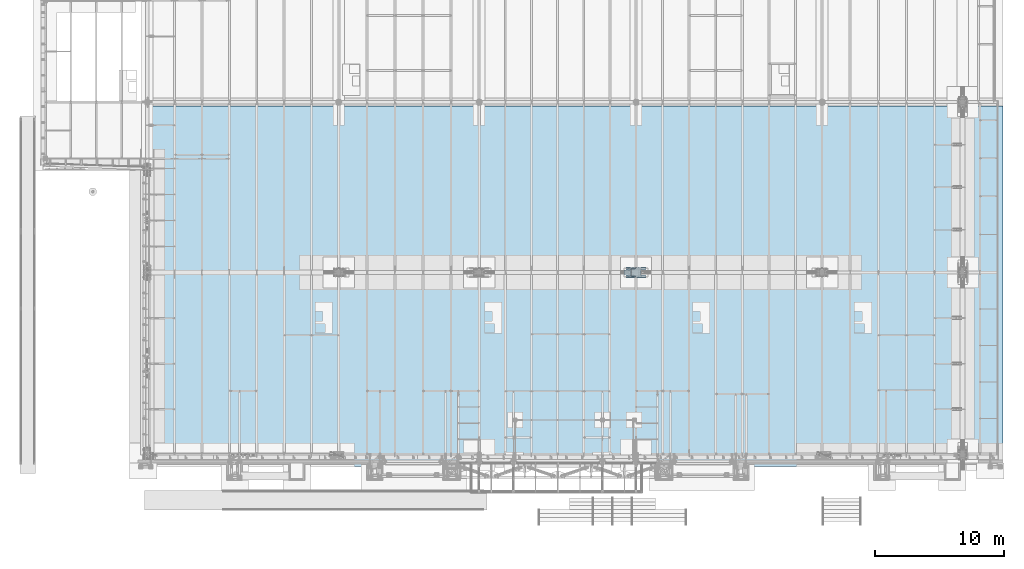
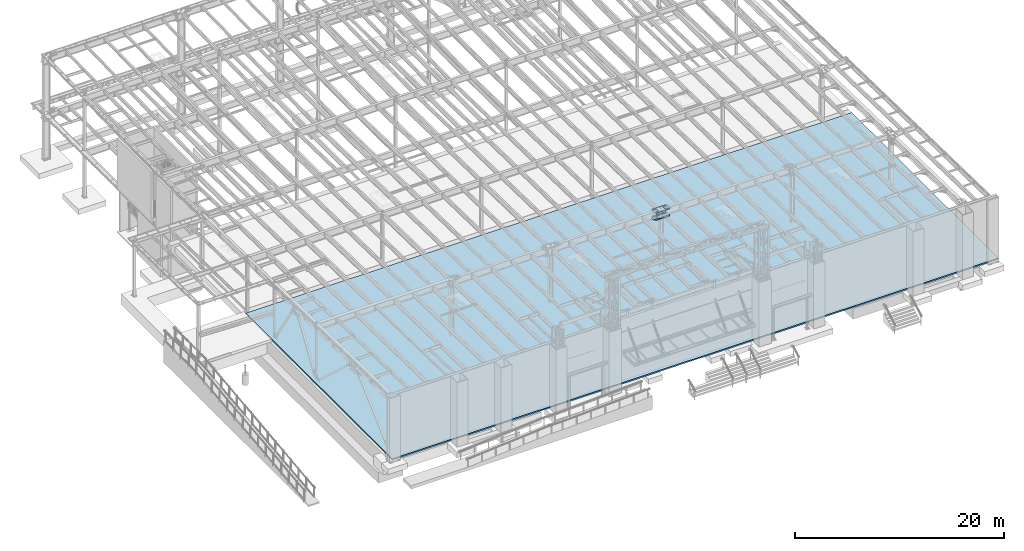
# One storey, part 1411 of 1763: 4 plates, 1 slab, 3 elements without a shape of their own.
"""IFC2X3 building model written with IfcOpenShell, lengths in millimetres."""

from ifc_helpers import new_model, si_unit, frame, origin_with_axes, place, context, subcontext, project, spatial, faceted_brep, material, type_object, element, aggregate, save


model = new_model("IFC2X3")

# Units and contexts
model_context = context("Model", 3, precision=1e-05, world=origin_with_axes())
body_context = subcontext(model_context, "Body", "Model", "MODEL_VIEW")
ifc_project = project(units=[si_unit("LENGTHUNIT", "METRE", prefix="MILLI"), si_unit("AREAUNIT", "SQUARE_METRE"), si_unit("VOLUMEUNIT", "CUBIC_METRE"), si_unit("MASSUNIT", "GRAM", prefix="KILO"), si_unit("TIMEUNIT", "SECOND"), si_unit("PLANEANGLEUNIT", "RADIAN"), si_unit("SOLIDANGLEUNIT", "STERADIAN"), si_unit("THERMODYNAMICTEMPERATUREUNIT", "DEGREE_CELSIUS"), si_unit("LUMINOUSINTENSITYUNIT", "LUMEN")], contexts=[model_context])

# Site, building, storey
site_placement = place(None, origin_with_axes())
site = spatial("IfcSite", under=ifc_project, at=site_placement, CompositionType="ELEMENT")
building_placement = place(site_placement, origin_with_axes())
building = spatial("IfcBuilding", under=site, at=building_placement, Name="Undefined", CompositionType="ELEMENT")
storey_placement = place(building_placement, origin_with_axes())
storey = spatial("IfcBuildingStorey", under=building, at=storey_placement, Name="Undefined", CompositionType="ELEMENT", Elevation=0.0)

# Assembly, plate
assembly_1_placement = place(storey_placement, origin_with_axes())
assembly_1 = element("IfcElementAssembly", 1, at=assembly_1_placement, inside=storey, Name="PLATE", AssemblyPlace="NOTDEFINED", PredefinedType="RIGID_FRAME")
ifc_material_1 = material(Name="STEEL/A572-50")
plate_type_1 = type_object("IfcPlateType", PredefinedType="NOTDEFINED")
plate_1_placement = place(assembly_1_placement, frame((-49446.8822232163, 96.8375244136021, 11057.4961714753), z_axis=(-1.0, 0.0, 0.0), x_axis=(0.0, 1.0, 0.0)))
plate_1 = element("IfcPlate", 2, at=plate_1_placement, type_object=plate_type_1, material=ifc_material_1, Name="PLATE", context=body_context, shape_type="Brep", body=[
    faceted_brep([(177.799939142153, -9.52499999999964, 479.364864346178), (177.799939142153, 9.52499999999964, 479.364864346178), (175.935192487686, 9.52499999999964, 467.591317332008), (175.935192487686, -9.52499999999964, 467.591317332008), (170.523486919264, 9.52499999999964, 456.97024713071), (170.523486919264, -9.52499999999964, 456.97024713071), (162.094557883494, 9.52499999999964, 448.541318094933), (162.094557883494, -9.52499999999964, 448.541318094933), (151.4734876822, 9.52499999999964, 443.1296125265), (151.4734876822, -9.52499999999964, 443.1296125265), (139.699940668032, 9.52499999999964, 441.264865872028), (139.699940668032, -9.52499999999964, 441.264865872028), (127.926386024366, 9.52499999999964, 443.1296125265), (127.926386024366, -9.52499999999964, 443.1296125265), (117.305315823075, 9.52499999999964, 448.541318094925), (117.305315823075, -9.52499999999964, 448.541318094925), (108.876386787306, 9.52499999999964, 456.970247130695), (108.876386787306, -9.52499999999964, 456.970247130695), (103.464681218881, 9.52499999999964, 467.591317331986), (103.464681218881, -9.52499999999964, 467.591317331986), (101.599934564408, 9.52499999999964, 479.364864346149), (101.599934564408, -9.52499999999964, 479.364864346149), (101.599934564408, 9.52499999999964, 600.014873502398), (101.599934564408, -9.52499999999964, 600.014873502398), (103.464681218941, 9.52499999999964, 611.788420516743), (103.464681218941, -9.52499999999964, 611.788420516743), (108.876386787534, 9.52499999999964, 622.409490718164), (108.876386787534, -9.52499999999964, 622.409490718164), (117.305315823547, 9.52499999999964, 630.838419753964), (117.305315823547, -9.52499999999964, 630.838419753964), (127.926386025105, 9.52499999999964, 636.25012532228), (127.926386025105, -9.52499999999964, 636.25012532228), (139.699940668921, 9.52499999999964, 638.114871976519), (139.699940668921, -9.52499999999964, 638.114871976519), (151.473487682847, 9.52499999999964, 636.250125321807), (151.473487682847, -9.52499999999964, 636.250125321807), (162.094557883867, 9.52499999999964, 630.83841975328), (162.094557883867, -9.52499999999964, 630.83841975328), (170.523486919393, 9.52499999999964, 622.409490717546), (170.523486919393, -9.52499999999964, 622.409490717546), (175.935192487652, 9.52499999999964, 611.788420516394), (175.935192487652, -9.52499999999964, 611.788420516394), (177.799939142071, 9.52499999999964, 600.01487350242), (177.799939142071, -9.52499999999964, 600.01487350242), (542.924972534173, -9.52499999999964, 885.855102539062), (542.924972534173, 9.52499999999964, 885.855102539062), (177.800003051751, 9.52499999999964, 885.855102539062), (177.800003051751, -9.52499999999964, 885.855063622585), (542.924972534173, -9.52499999999964, 752.414870449502), (542.924972534173, 9.52499999999964, 752.414870449502), (544.789719188646, -9.52499999999964, 740.641323435339), (544.789719188646, 9.52499999999964, 740.641323435339), (550.20142475707, -9.52499999999964, 730.020253234048), (550.20142475707, 9.52499999999964, 730.020253234048), (558.63035379284, -9.52499999999964, 721.591324198278), (558.63035379284, 9.52499999999964, 721.591324198278), (569.251423994131, -9.52499999999964, 716.179618629852), (569.251423994131, 9.52499999999964, 716.179618629852), (581.024971008294, -9.52499999999964, 714.314871975381), (581.024971008294, 9.52499999999964, 714.314871975381), (720.724975586481, -9.52499999999964, 714.314871975381), (720.724975585938, 9.52499999999964, 714.314871975381), (720.724975585938, -9.52499999999964, 7.27595761418343e-12), (720.724975585938, 9.52499999999964, 7.27595761418343e-12), (619.125, -9.52499999999964, 0.0), (619.125, 9.52499999999964, 0.0), (619.124958978549, -9.52499999999964, 326.964881896973), (619.124958978549, 9.52499999999964, 326.964881896973), (617.260212324076, -9.52499999999964, 338.738428911136), (617.260212324076, 9.52499999999964, 338.738428911136), (611.848506755652, -9.52499999999964, 349.359499112426), (611.848506755652, 9.52499999999964, 349.359499112426), (603.419577719882, -9.52499999999964, 357.788428148197), (603.419577719882, 9.52499999999964, 357.788428148197), (592.798507518591, -9.52499999999964, 363.200133716622), (592.798507518591, 9.52499999999964, 363.200133716622), (581.024960504428, -9.52499999999964, 365.064880371094), (581.024960504428, 9.52499999999964, 365.064880371094), (139.699933038564, -9.52499999999964, 365.064880371094), (139.699933038564, 9.52499999999964, 365.064880371094), (127.9263860244, -9.52499999999964, 363.200133716622), (127.9263860244, 9.52499999999964, 363.200133716622), (117.305315823109, -9.52499999999964, 357.788428148197), (117.305315823109, 9.52499999999964, 357.788428148197), (108.876386787339, -9.52499999999964, 349.359499112426), (108.876386787339, 9.52499999999964, 349.359499112426), (103.464681218915, -9.52499999999964, 338.738428911129), (103.464681218915, 9.52499999999964, 338.738428911129), (101.599934564443, -9.52499999999964, 326.964881896965), (101.599934564443, 9.52499999999964, 326.964881896965), (101.599934564487, -9.52499999999964, 0.0), (101.599934564487, 9.52499999999964, 0.0), (0.0, -9.52500000000146, 0.0), (0.0, 9.52500000000146, 0.0), (-3.68345354218036e-11, -9.52499999999964, 714.314871972194), (-3.68345354218036e-11, 9.52499999999964, 714.314871972194), (139.700004577691, -9.52499999999964, 714.314871972194), (139.700004577691, 9.52499999999964, 714.314871972194), (151.473551591857, -9.52499999999964, 716.179618626666), (151.473551591857, 9.52499999999964, 716.179618626666), (162.094621793151, -9.52499999999964, 721.591324195098), (162.094621793151, 9.52499999999964, 721.591324195098), (170.523550828921, -9.52499999999964, 730.020253230869), (170.523550828921, 9.52499999999964, 730.020253230869), (175.935256397344, -9.52499999999964, 740.641323432166), (175.935256397344, 9.52499999999964, 740.641323432166), (177.800003051812, -9.52499999999964, 752.41487044633), (177.800003051812, 9.52499999999964, 752.41487044633), (617.260212324486, -9.52499999999964, 467.591317332102), (611.848506756063, -9.52499999999964, 456.970247130805), (603.419577720293, -9.52499999999964, 448.541318095035), (592.798507519, -9.52499999999964, 443.129612526602), (581.024960504833, -9.52499999999964, 441.26486587213), (569.251405861195, -9.52499999999964, 443.129612526602), (558.630335659904, -9.52499999999964, 448.541318095027), (550.201406624135, -9.52499999999964, 456.970247130797), (544.78970105571, -9.52499999999964, 467.591317332088), (542.924954401237, -9.52499999999964, 479.364864346251), (542.924954401237, -9.52499999999964, 600.014873502478), (544.789701055769, -9.52499999999964, 611.788420516823), (550.201406624359, -9.52499999999964, 622.409490718237), (558.630335660367, -9.52499999999964, 630.838419754036), (569.25140586192, -9.52499999999964, 636.25012532236), (581.024960505725, -9.52499999999964, 638.114871976599), (592.798507519656, -9.52499999999964, 636.250125321894), (603.419577720682, -9.52499999999964, 630.838419753367), (611.848506756213, -9.52499999999964, 622.409490717633), (617.260212324474, -9.52499999999964, 611.788420516474), (619.124958978893, -9.52499999999964, 600.0148735025), (619.124958978954, -9.52499999999964, 479.364864346273), (611.848506756213, 9.52499999999964, 622.409490717633), (617.260212324474, 9.52499999999964, 611.788420516474), (603.419577720682, 9.52499999999964, 630.838419753367), (592.798507519656, 9.52499999999964, 636.250125321894), (581.024960505725, 9.52499999999964, 638.114871976599), (569.25140586192, 9.52499999999964, 636.25012532236), (558.630335660367, 9.52499999999964, 630.838419754036), (550.201406624359, 9.52499999999964, 622.409490718237), (544.789701055769, 9.52499999999964, 611.788420516823), (542.924954401237, 9.52499999999964, 600.014873502478), (542.924954401237, 9.52499999999964, 479.364864346251), (544.78970105571, 9.52499999999964, 467.591317332088), (550.201406624135, 9.52499999999964, 456.970247130797), (558.630335659904, 9.52499999999964, 448.541318095027), (569.251405861195, 9.52499999999964, 443.129612526602), (581.024960504833, 9.52499999999964, 441.26486587213), (592.798507519, 9.52499999999964, 443.129612526602), (603.419577720293, 9.52499999999964, 448.541318095035), (611.848506756063, 9.52499999999964, 456.970247130805), (617.260212324486, 9.52499999999964, 467.591317332102), (619.124958978954, 9.52499999999964, 479.364864346273), (619.124958978893, 9.52499999999964, 600.0148735025)], [[[0, 1, 2, 3]], [[3, 2, 4, 5]], [[5, 4, 6, 7]], [[7, 6, 8, 9]], [[9, 8, 10, 11]], [[11, 10, 12, 13]], [[13, 12, 14, 15]], [[15, 14, 16, 17]], [[17, 16, 18, 19]], [[19, 18, 20, 21]], [[21, 20, 22, 23]], [[23, 22, 24, 25]], [[25, 24, 26, 27]], [[27, 26, 28, 29]], [[29, 28, 30, 31]], [[31, 30, 32, 33]], [[33, 32, 34, 35]], [[35, 34, 36, 37]], [[37, 36, 38, 39]], [[39, 38, 40, 41]], [[41, 40, 42, 43]], [[43, 42, 1, 0]], [[44, 45, 46, 47]], [[44, 48, 49, 45]], [[50, 51, 49, 48]], [[52, 53, 51, 50]], [[54, 55, 53, 52]], [[56, 57, 55, 54]], [[58, 59, 57, 56]], [[60, 61, 59, 58]], [[62, 63, 61, 60]], [[63, 62, 64, 65]], [[66, 67, 65, 64]], [[68, 69, 67, 66]], [[70, 71, 69, 68]], [[72, 73, 71, 70]], [[74, 75, 73, 72]], [[76, 77, 75, 74]], [[78, 79, 77, 76]], [[80, 81, 79, 78]], [[82, 83, 81, 80]], [[84, 85, 83, 82]], [[86, 87, 85, 84]], [[88, 89, 87, 86]], [[90, 91, 89, 88]], [[92, 93, 91, 90]], [[93, 92, 94, 95]], [[96, 97, 95, 94]], [[98, 99, 97, 96]], [[100, 101, 99, 98]], [[102, 103, 101, 100]], [[104, 105, 103, 102]], [[106, 107, 105, 104]], [[47, 46, 107, 106]], [[104, 102, 100, 98, 96, 94, 92, 90, 88, 86, 84, 82, 80, 78, 76, 74, 72, 70, 68, 66, 64, 62, 60, 58, 56, 54, 52, 50, 48, 44, 47, 106], [3, 5, 7, 9, 11, 13, 15, 17, 19, 21, 23, 25, 27, 29, 31, 33, 35, 37, 39, 41, 43, 0], [108, 109, 110, 111, 112, 113, 114, 115, 116, 117, 118, 119, 120, 121, 122, 123, 124, 125, 126, 127, 128, 129]], [[126, 130, 131, 127]], [[125, 132, 130, 126]], [[124, 133, 132, 125]], [[123, 134, 133, 124]], [[122, 135, 134, 123]], [[121, 136, 135, 122]], [[120, 137, 136, 121]], [[119, 138, 137, 120]], [[118, 139, 138, 119]], [[117, 140, 139, 118]], [[116, 141, 140, 117]], [[115, 142, 141, 116]], [[114, 143, 142, 115]], [[113, 144, 143, 114]], [[112, 145, 144, 113]], [[111, 146, 145, 112]], [[110, 147, 146, 111]], [[109, 148, 147, 110]], [[108, 149, 148, 109]], [[129, 150, 149, 108]], [[128, 151, 150, 129]], [[127, 131, 151, 128]], [[45, 49, 51, 53, 55, 57, 59, 61, 63, 65, 67, 69, 71, 73, 75, 77, 79, 81, 83, 85, 87, 89, 91, 93, 95, 97, 99, 101, 103, 105, 107, 46], [38, 36, 34, 32, 30, 28, 26, 24, 22, 20, 18, 16, 14, 12, 10, 8, 6, 4, 2, 1, 42, 40], [130, 132, 133, 134, 135, 136, 137, 138, 139, 140, 141, 142, 143, 144, 145, 146, 147, 148, 149, 150, 151, 131]]]),
])
aggregate(assembly_1, [plate_1])

# Assembly, plates
assembly_2_placement = place(storey_placement, origin_with_axes())
assembly_2 = element("IfcElementAssembly", 3, at=assembly_2_placement, inside=storey, Name="COLUMN", AssemblyPlace="NOTDEFINED", PredefinedType="RIGID_FRAME")
plate_type_2 = type_object("IfcPlateType", PredefinedType="NOTDEFINED")
plate_2_placement = place(assembly_2_placement, frame((-48643.5972372495, 80.9624876158953, 11076.5461722221), z_axis=(-1.0, 0.0, 0.0), x_axis=(0.0, 1.0, 0.0)))
plate_2 = element("IfcPlate", 4, at=plate_2_placement, type_object=plate_type_2, material=ifc_material_1, Name="PLATE", context=body_context, shape_type="Brep", body=[
    faceted_brep([(0.0, -9.52500000000146, 0.0), (6.09866367682343e-05, -9.52499999932661, 1517.67492675778), (6.09866367398126e-05, 9.52500000067266, 1517.67492675785), (0.0, 9.52500000000146, 0.0), (139.700042724606, -9.52499999926476, 1517.67492675735), (139.700042724606, 9.52500000073451, 1517.67492675742), (139.700012207031, -9.52499999993779, -4.65661287307739e-10), (139.700012207031, 9.52500000006148, -3.92901711165905e-10)], [[[0, 1, 2, 3]], [[1, 4, 5, 2]], [[4, 6, 7, 5]], [[6, 0, 3, 7]], [[5, 7, 3, 2]], [[6, 4, 1, 0]]]),
])
plate_3_placement = place(assembly_2_placement, frame((-48643.59723725, 833.437499990867, 11076.5461722221), z_axis=(-1.0, 0.0, 0.0), x_axis=(0.0, -1.0, 0.0)))
plate_3 = element("IfcPlate", 5, at=plate_3_placement, type_object=plate_type_2, material=ifc_material_1, Name="PLATE", context=body_context, shape_type="Brep", body=[
    faceted_brep([(0.0, -9.52500000000146, 0.0), (6.09866367682343e-05, -9.52499999932661, 1517.67492675778), (6.09866367398126e-05, 9.52500000067266, 1517.67492675785), (0.0, 9.52500000000146, 0.0), (139.700042724606, -9.52499999926476, 1517.67492675735), (139.700042724606, 9.52500000073451, 1517.67492675742), (139.700012207031, -9.52499999993779, -4.65661287307739e-10), (139.700012207031, 9.52500000006148, -3.92901711165905e-10)], [[[0, 1, 2, 3]], [[1, 4, 5, 2]], [[4, 6, 7, 5]], [[6, 0, 3, 7]], [[5, 7, 3, 2]], [[6, 4, 1, 0]]]),
])
plate_type_3 = type_object("IfcPlateType", PredefinedType="NOTDEFINED")
plate_4_placement = place(assembly_2_placement, frame((-48643.5972569009, 80.9624999904923, 11898.871171802), z_axis=(-1.0, 0.0, 0.0), x_axis=(0.0, 1.0, 0.0)))
plate_4 = element("IfcPlate", 6, at=plate_4_placement, type_object=plate_type_3, material=ifc_material_1, Name="PLATE", context=body_context, shape_type="Brep", body=[
    faceted_brep([(139.699983846479, -9.52499999993597, 1517.67492675781), (139.699981655651, -9.52499999993597, 1152.5400164259), (139.69998167471, 9.5250000000633, 1152.54001646402), (139.699983865537, 9.5250000000633, 1517.67492675781), (141.633441394212, -9.52499999993597, 1142.8198574948), (141.633441413271, 9.52500000006512, 1142.81985753292), (147.139469015552, -9.52499999993233, 1134.57950458732), (147.139469034611, 9.52500000006694, 1134.57950462543), (155.379821747524, -9.5249999999287, 1129.07347670331), (155.379821766582, 9.52500000007058, 1129.07347674143), (165.099980617002, -9.52499999992506, 1127.14001665491), (165.09998063606, 9.52500000007421, 1127.14001669303), (587.374993587002, -9.5249999997377, 1127.14000572819), (587.374993606061, 9.52500000026157, 1127.1400057663), (597.0951527897, -9.52499999973406, 1129.07346537014), (597.095152808758, 9.52500000026703, 1129.07346540826), (605.33550593034, -9.52499999973043, 1134.57949308804), (605.335505949398, 9.52500000027067, 1134.57949312615), (610.841533910914, -9.52499999972679, 1142.81984605316), (610.841533929972, 9.52500000027248, 1142.81984609128), (612.774993862712, -9.52499999972679, 1152.54000519422), (612.77499388177, 9.52500000027248, 1152.54000523234), (612.774996053967, -9.52499999972679, 1517.67491718032), (612.774996073025, 9.52500000027248, 1517.67492675781), (0.0, -9.52500000000146, 0.0), (6.09866367682343e-05, -9.52499999932661, 1517.67492675778), (6.09866367398126e-05, 9.52500000067266, 1517.67492675785), (0.0, 9.52500000000146, 0.0), (139.700012207031, -9.52499999993779, -4.65661287307739e-10), (139.700012207031, 9.52500000006148, -3.92901711165905e-10), (139.699983713167, 9.5250000000633, 365.140060303551), (139.699983694108, -9.52499999993597, 365.14006043689), (141.633443616664, 9.52500000006512, 374.860219328031), (141.633443597606, -9.52499999993597, 374.86021946137), (147.139471467063, 9.52500000006694, 383.100572231291), (147.139471448004, -9.52499999993233, 383.10057236463), (155.379824436406, 9.52500000007058, 388.606599982784), (155.379824417348, -9.5249999999287, 388.606600116123), (165.099983484098, 9.52500000007421, 390.540059769613), (165.09998346504, -9.52499999992506, 390.540059902953), (587.37499645473, 9.52500000026157, 390.540057234837), (587.374996435672, -9.5249999997377, 390.540057368176), (597.095155479231, 9.52500000026703, 388.606597331309), (597.095155460173, -9.52499999973406, 388.606597464648), (605.335508382508, 9.52500000027067, 383.100569480877), (605.335508363449, -9.52499999973043, 383.100569614217), (610.841536134018, 9.52500000027248, 374.860216511501), (610.84153611496, -9.52499999972679, 374.86021664484), (612.774995920859, 9.52500000027248, 365.140057463788), (612.774995901801, -9.52499999972679, 365.140057597127), (612.774993729339, 9.52500000027248, 0.0), (612.774993710281, -9.52499999972679, 0.0), (752.474975585938, 9.52500000033433, 0.0), (752.474975585938, -9.52499999966494, 0.0), (752.474975585938, -9.52499999966494, 1517.67492675781), (752.474975585938, 9.52500000033433, 1517.67492675781)], [[[0, 1, 2, 3]], [[4, 5, 2, 1]], [[6, 7, 5, 4]], [[8, 9, 7, 6]], [[10, 11, 9, 8]], [[12, 13, 11, 10]], [[14, 15, 13, 12]], [[16, 17, 15, 14]], [[18, 19, 17, 16]], [[20, 21, 19, 18]], [[22, 23, 21, 20]], [[24, 25, 26, 27]], [[28, 24, 27, 29]], [[28, 29, 30, 31]], [[31, 30, 32, 33]], [[33, 32, 34, 35]], [[35, 34, 36, 37]], [[37, 36, 38, 39]], [[39, 38, 40, 41]], [[41, 40, 42, 43]], [[43, 42, 44, 45]], [[45, 44, 46, 47]], [[47, 46, 48, 49]], [[49, 48, 50, 51]], [[52, 53, 51, 50]], [[54, 53, 52, 55]], [[18, 16, 14, 12, 10, 8, 6, 4, 1, 0, 25, 24, 28, 31, 33, 35, 37, 39, 41, 43, 45, 47, 49, 51, 53, 54, 22, 20]], [[26, 25, 0, 3]], [[55, 52, 50, 48, 46, 44, 42, 40, 38, 36, 34, 32, 30, 29, 27, 26, 3, 2, 5, 7, 9, 11, 13, 15, 17, 19, 21, 23]], [[54, 55, 23, 22]]]),
])
aggregate(assembly_2, [plate_2, plate_4, plate_3])

# Assembly, slab
assembly_3_placement = place(storey_placement, origin_with_axes())
assembly_3 = element("IfcElementAssembly", 7, at=assembly_3_placement, inside=storey, Name="SLAB", AssemblyPlace="NOTDEFINED", PredefinedType="REINFORCEMENT_UNIT")
ifc_material_2 = material(Name="CONCRETE/3000")
slab_type = type_object("IfcSlabType", PredefinedType="NOTDEFINED")
slab_placement = place(assembly_3_placement, frame((-87731.0372736984, 13385.8, 5257.8), z_axis=(1.0, 0.0, 0.0), x_axis=(0.0, -1.0, 0.0)))
slab = element("IfcSlab", 8, at=slab_placement, type_object=slab_type, material=ifc_material_2, Name="SLAB", PredefinedType="FLOOR", context=body_context, shape_type="Brep", body=[
    faceted_brep([(0.0, -76.2, 0.0), (0.0, -76.1999999999998, 66852.8046875), (0.0, 76.1999999999998, 66852.8046875), (0.0, 76.2, 0.0), (28016.19921875, -76.1999999999998, 66852.8046875), (28016.19921875, 76.1999999999998, 66852.8046875), (28016.19921875, -76.1999999999998, 0.0), (28016.19921875, 76.1999999999998, 0.0)], [[[0, 1, 2, 3]], [[1, 4, 5, 2]], [[4, 6, 7, 5]], [[6, 0, 3, 7]], [[5, 7, 3, 2]], [[6, 4, 1, 0]]]),
])
aggregate(assembly_3, [slab])

save(model, "model.ifc")
